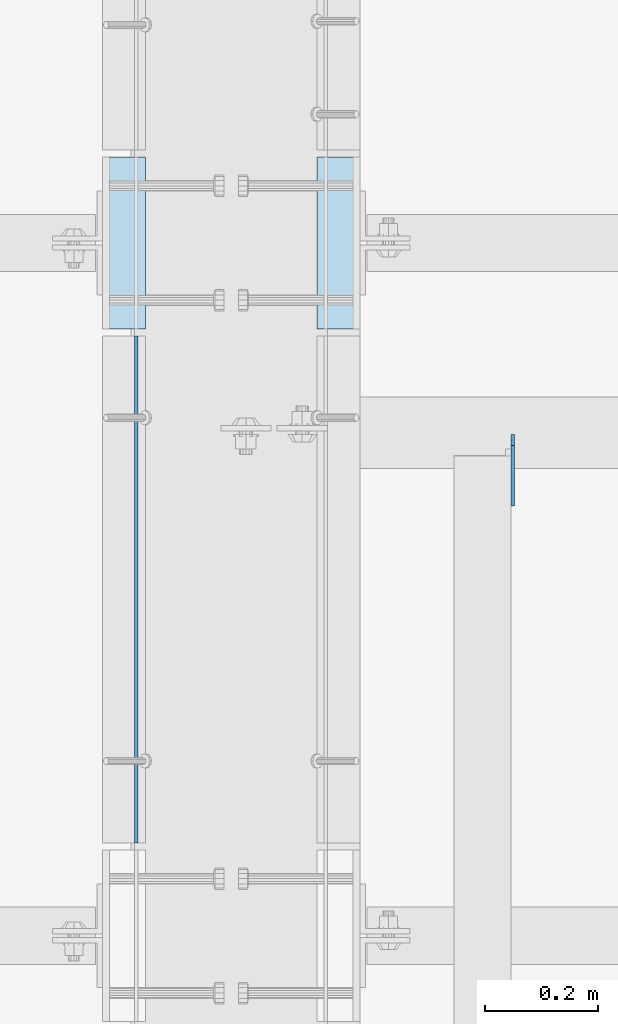
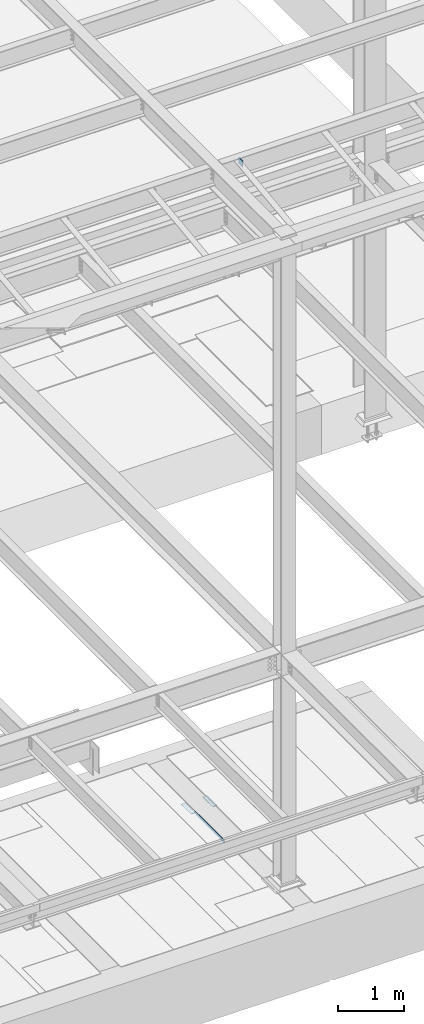
# One storey, part 3164 of 3843: 4 plates, 4 elements without a shape of their own.
"""IFC2X3 building model written with IfcOpenShell, lengths in millimetres."""

from ifc_helpers import new_model, si_unit, frame, origin_with_axes, place, context, subcontext, project, spatial, faceted_brep, material, type_object, element, aggregate, save


model = new_model("IFC2X3")

# Units and contexts
model_context = context("Model", 3, precision=1e-05, world=origin_with_axes())
body_context = subcontext(model_context, "Body", "Model", "MODEL_VIEW")
ifc_project = project(units=[si_unit("LENGTHUNIT", "METRE", prefix="MILLI"), si_unit("AREAUNIT", "SQUARE_METRE"), si_unit("VOLUMEUNIT", "CUBIC_METRE"), si_unit("MASSUNIT", "GRAM", prefix="KILO"), si_unit("TIMEUNIT", "SECOND"), si_unit("PLANEANGLEUNIT", "RADIAN"), si_unit("SOLIDANGLEUNIT", "STERADIAN"), si_unit("THERMODYNAMICTEMPERATUREUNIT", "DEGREE_CELSIUS"), si_unit("LUMINOUSINTENSITYUNIT", "LUMEN")], contexts=[model_context])

# Site, building, storey
site_placement = place(None, origin_with_axes())
site = spatial("IfcSite", under=ifc_project, at=site_placement, CompositionType="ELEMENT")
building_placement = place(site_placement, origin_with_axes())
building = spatial("IfcBuilding", under=site, at=building_placement, Name="Undefined", CompositionType="ELEMENT")
storey_placement = place(building_placement, origin_with_axes())
storey = spatial("IfcBuildingStorey", under=building, at=storey_placement, Name="Undefined", CompositionType="ELEMENT", Elevation=0.0)

# Assembly, plate
assembly_1_placement = place(storey_placement, origin_with_axes())
assembly_1 = element("IfcElementAssembly", 1, at=assembly_1_placement, inside=storey, Name="EMBED PLATE", AssemblyPlace="NOTDEFINED", PredefinedType="RIGID_FRAME")
ifc_material_1 = material(Name="STEEL/A36")
plate_type_1 = type_object("IfcPlateType", PredefinedType="NOTDEFINED")
plate_1_placement = place(assembly_1_placement, frame((62331.5999969482, 17306.925, 30426.025), z_axis=(0.0, 1.0, 0.0), x_axis=(1.0, 0.0, 0.0)))
plate_1 = element("IfcPlate", 2, at=plate_1_placement, type_object=plate_type_1, material=ifc_material_1, Name="PLATE", context=body_context, shape_type="Brep", body=[
    faceted_brep([(0.0, -3.17499999999927, 0.0), (0.0, -3.17499999999927, 304.800000000003), (0.0, 3.17499999999927, 304.800000000003), (0.0, 3.17499999999927, 0.0), (76.1999999999971, -3.17499999999927, 304.799999999996), (76.1999999999971, 3.17499999999927, 304.799999999996), (76.1999999999971, -3.17499999999927, 0.0), (76.1999999999971, 3.17499999999927, 0.0)], [[[0, 1, 2, 3]], [[1, 4, 5, 2]], [[4, 6, 7, 5]], [[6, 0, 3, 7]], [[5, 7, 3, 2]], [[6, 4, 1, 0]]]),
])
aggregate(assembly_1, [plate_1])

assembly_2_placement = place(storey_placement, origin_with_axes())
assembly_2 = element("IfcElementAssembly", 3, at=assembly_2_placement, inside=storey, Name="EMBED PLATE", AssemblyPlace="NOTDEFINED", PredefinedType="RIGID_FRAME")
plate_2_placement = place(assembly_2_placement, frame((62788.8000030518, 17611.725, 30426.025), z_axis=(0.0, -1.0, 0.0), x_axis=(-1.0, 0.0, 0.0)))
plate_2 = element("IfcPlate", 4, at=plate_2_placement, type_object=plate_type_1, material=ifc_material_1, Name="PLATE", context=body_context, shape_type="Brep", body=[
    faceted_brep([(0.0, -3.17499999999927, 0.0), (0.0, -3.17499999999927, 304.800000000003), (0.0, 3.17499999999927, 304.800000000003), (0.0, 3.17499999999927, 0.0), (76.1999999999971, -3.17499999999927, 304.799999999996), (76.1999999999971, 3.17499999999927, 304.799999999996), (76.1999999999971, -3.17499999999927, 0.0), (76.1999999999971, 3.17499999999927, 0.0)], [[[0, 1, 2, 3]], [[1, 4, 5, 2]], [[4, 6, 7, 5]], [[6, 0, 3, 7]], [[5, 7, 3, 2]], [[6, 4, 1, 0]]]),
])
aggregate(assembly_2, [plate_2])

assembly_3_placement = place(storey_placement, origin_with_axes())
assembly_3 = element("IfcElementAssembly", 5, at=assembly_3_placement, inside=storey, Name="ANGLE", AssemblyPlace="NOTDEFINED", PredefinedType="RIGID_FRAME")
plate_type_2 = type_object("IfcPlateType", PredefinedType="NOTDEFINED")
plate_3_placement = place(assembly_3_placement, frame((62391.9250016876, 16394.1125001871, 30429.2000030518), z_axis=(0.0, 0.999999999997942, -2.02899998962774e-06), x_axis=(0.0, 2.02899999567308e-06, 0.999999999997942)))
plate_3 = element("IfcPlate", 6, at=plate_3_placement, type_object=plate_type_2, material=ifc_material_1, Name="PLATE", context=body_context, shape_type="Brep", body=[
    faceted_brep([(0.0, -3.17499999999927, 0.0), (0.00181156927283155, -3.1749999984022, 900.111999510274), (0.00181156927283155, 3.17500000159635, 900.11199951026), (0.0, 3.17499999999927, 0.0), (50.8018112192949, -3.1749999984022, 900.111999510213), (50.8018112192949, 3.17500000159635, 900.111999510198), (50.7999954217848, -3.17499999999563, -7.27595761418343e-12), (50.7999954217848, 3.17500000001019, -1.09139364212751e-11)], [[[0, 1, 2, 3]], [[1, 4, 5, 2]], [[4, 6, 7, 5]], [[6, 0, 3, 7]], [[5, 7, 3, 2]], [[6, 4, 1, 0]]]),
])
aggregate(assembly_3, [plate_3])

assembly_4_placement = place(storey_placement, origin_with_axes())
assembly_4 = element("IfcElementAssembly", 7, at=assembly_4_placement, inside=storey, Name="BEAM", AssemblyPlace="NOTDEFINED", PredefinedType="RIGID_FRAME")
ifc_material_2 = material(Name="STEEL/A572-50")
plate_type_3 = type_object("IfcPlateType", PredefinedType="NOTDEFINED")
plate_4_placement = place(assembly_4_placement, frame((63060.2625, 17118.965, 42330.6875), z_axis=(0.0, 0.0, 1.0), x_axis=(0.0, -1.0, 0.0)))
plate_4 = element("IfcPlate", 8, at=plate_4_placement, type_object=plate_type_3, material=ifc_material_2, Name="PLATE", context=body_context, shape_type="Brep", body=[
    faceted_brep([(0.0, -3.17499999999927, 0.0), (0.0, -3.17500000000291, 107.950000000004), (0.0, 3.17500000000291, 107.950000000004), (0.0, 3.17499999999927, 0.0), (19.0500000000029, -3.17500000000291, 127.0), (19.0500000000029, 3.17500000000291, 127.0), (127.0, -3.17500000000291, 127.0), (127.0, 3.17500000000291, 127.0), (127.0, -3.17500000000291, 0.0), (127.0, 3.17500000000291, 0.0)], [[[0, 1, 2, 3]], [[1, 4, 5, 2]], [[4, 6, 7, 5]], [[6, 8, 9, 7]], [[8, 0, 3, 9]], [[5, 7, 9, 3, 2]], [[8, 6, 4, 1, 0]]]),
])
aggregate(assembly_4, [plate_4])

save(model, "model.ifc")
